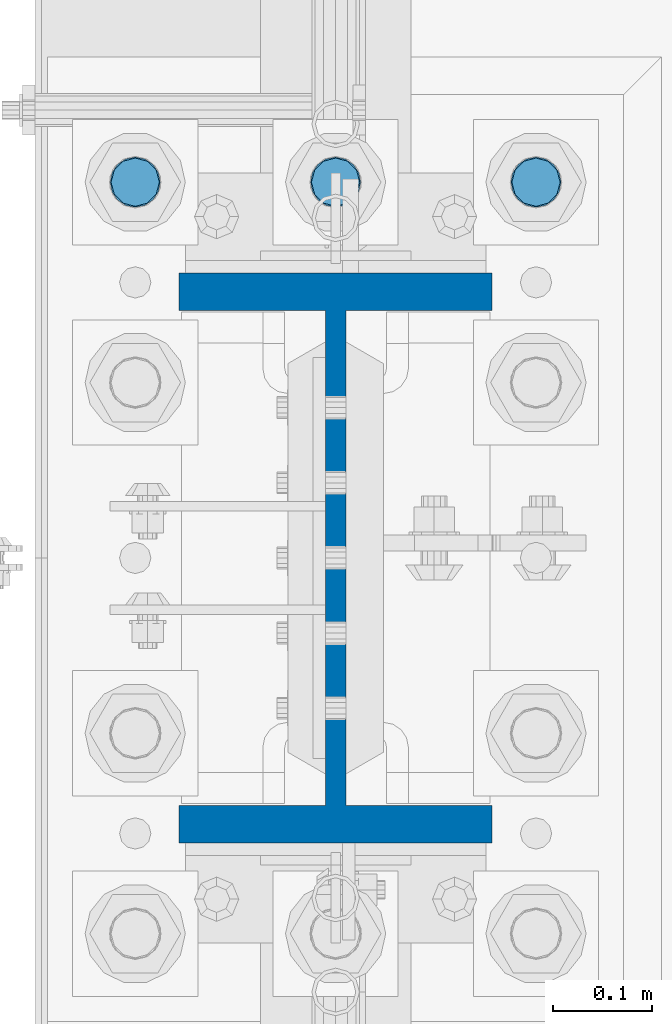
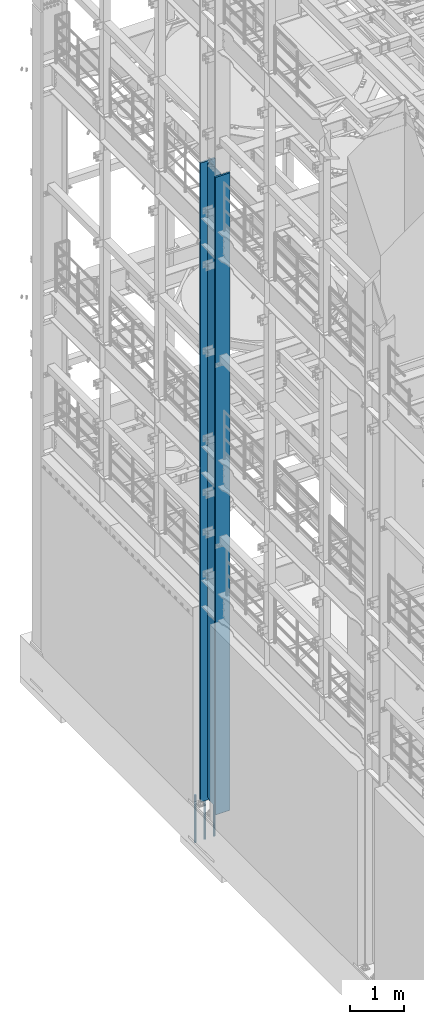
# One storey, part 732 of 1876: 4 columns, 2 elements without a shape of their own.
"""IFC2X3 building model written with IfcOpenShell, lengths in millimetres."""

from ifc_helpers import new_model, si_unit, frame, origin_with_axes, place, context, subcontext, project, spatial, faceted_brep, material, type_object, element, aggregate, save


model = new_model("IFC2X3")

# Units and contexts
model_context = context("Model", 3, precision=1e-05, world=origin_with_axes())
body_context = subcontext(model_context, "Body", "Model", "MODEL_VIEW")
ifc_project = project(units=[si_unit("LENGTHUNIT", "METRE", prefix="MILLI"), si_unit("AREAUNIT", "SQUARE_METRE"), si_unit("VOLUMEUNIT", "CUBIC_METRE"), si_unit("MASSUNIT", "GRAM", prefix="KILO"), si_unit("TIMEUNIT", "SECOND"), si_unit("PLANEANGLEUNIT", "RADIAN"), si_unit("SOLIDANGLEUNIT", "STERADIAN"), si_unit("THERMODYNAMICTEMPERATUREUNIT", "DEGREE_CELSIUS"), si_unit("LUMINOUSINTENSITYUNIT", "LUMEN")], contexts=[model_context])

# Site, building, storey
site_placement = place(None, origin_with_axes())
site = spatial("IfcSite", under=ifc_project, at=site_placement, CompositionType="ELEMENT")
building_placement = place(site_placement, origin_with_axes())
building = spatial("IfcBuilding", under=site, at=building_placement, Name="Undefined", CompositionType="ELEMENT")
storey_placement = place(building_placement, origin_with_axes())
storey = spatial("IfcBuildingStorey", under=building, at=storey_placement, Name="Undefined", CompositionType="ELEMENT", Elevation=0.0)

# Assembly, column
assembly_1_placement = place(storey_placement, origin_with_axes())
assembly_1 = element("IfcElementAssembly", 1, at=assembly_1_placement, inside=storey, Name="COLUMN", AssemblyPlace="NOTDEFINED", PredefinedType="RIGID_FRAME")
ifc_material_1 = material(Name="STEEL/A992")
column_type_1 = type_object("IfcColumnType", Name="W21X182", PredefinedType="NOTDEFINED")
column_1_placement = place(assembly_1_placement, frame((0.0, 7620.0, 0.0), z_axis=(0.0, 1.0, 0.0), x_axis=(0.0, 0.0, 1.0)))
column_1 = element("IfcColumn", 2, at=column_1_placement, type_object=column_type_1, material=ifc_material_1, Name="COLUMN", ObjectType="W21X182", context=body_context, shape_type="Brep", body=[
    faceted_brep([(115.887500412823, -10.3187499999967, 200.025000762939), (95.25, 10.31875, 200.025000762939), (95.25, 10.31875, -200.025000762939), (115.887500412823, -10.31875, -200.025000762939), (14528.8, -158.75, 288.925), (14528.8, 158.75, 288.925), (133.350000412822, 158.75, 288.925), (133.350000412824, -158.75, 288.925), (146.050000412824, -158.75, 250.825), (14478.0, -158.75, 250.825), (14528.8, -158.75, 250.825), (95.25, -158.75, 250.825), (146.050000412823, -10.3187500000004, 250.825), (14478.0, -10.3187500000004, 250.825), (14528.8, -10.3187500000004, 250.825), (95.25, -10.3187500000004, 250.825), (14528.8, -158.75, -288.925), (14528.8, -158.75, -250.825), (14478.0000007629, -158.75, -250.825), (146.050000412824, -158.75, -250.825), (95.25, -158.75, -250.825), (133.350000412824, -158.75, -288.925), (14528.8, 158.75, -288.925), (133.350000412822, 158.75, -288.925), (146.050000412824, 158.75, -250.825), (14478.0000007629, 158.75, -250.825), (14528.8, 158.75, -250.825), (95.25, 158.75, -250.825), (14528.8, 10.3187500000004, -250.825), (14528.8, -10.3187500000004, -250.825), (14478.0000007629, -10.3187500000004, -250.825), (146.050000412824, -10.3187500000004, -250.825), (95.25, -10.3187500000004, -250.825), (120.650000794293, -10.3187500000004, -200.025000762939), (120.650000794293, 10.3187500000004, -200.025000762939), (130.370159830384, 10.3187500000004, -201.958460608115), (130.370159830384, -10.3187500000004, -201.958460608115), (138.610512766692, 10.3187500000004, -207.464488409071), (138.610512766692, -10.3187500000004, -207.464488409071), (144.116540567648, 10.3187500000004, -215.704841345378), (144.116540567648, -10.3187500000004, -215.704841345378), (146.050000412823, 10.3187500000004, -225.42500038147), (146.050000412823, -10.3187500000004, -225.42500038147), (146.050000412824, 10.3187500000004, -250.825), (95.25, 10.3187500000004, -250.825), (14478.0000007629, 10.3187500000004, -250.825), (14481.8669204533, 10.3187500000004, -231.384681927818), (14481.8669204533, -10.3187500000004, -231.384681927818), (14492.8789760552, 10.3187500000004, -214.903976055203), (14492.8789760552, -10.3187500000004, -214.903976055203), (14509.3596819278, 10.3187500000004, -203.891920453291), (14509.3596819278, -10.3187500000004, -203.891920453291), (14528.8, -10.3187500000004, -200.025000762939), (14528.8, 10.3187500000004, -200.025000762939), (14528.8, 10.3187500000004, 200.025000762939), (14528.8, -10.3187500000004, 200.025000762939), (14509.3596811649, 10.3187500000004, 203.891920453291), (14509.3596811649, -10.3187500000004, 203.891920453291), (14492.8789752923, 10.3187500000004, 214.903976055203), (14492.8789752923, -10.3187500000004, 214.903976055203), (14481.8669196904, 10.3187500000004, 231.384681927818), (14481.8669196904, -10.3187500000004, 231.384681927818), (14478.0, 10.3187500000004, 250.825), (14528.8, 10.3187500000004, 250.825), (14528.8, 158.75, 250.825), (14478.0, 158.75, 250.825), (146.050000412824, 158.75, 250.825), (95.25, 158.75, 250.825), (95.25, 10.3187500000004, 250.825), (146.050000412824, 10.3187500000004, 250.825), (146.050000412823, 10.3187500000004, 225.42500038147), (146.050000412823, -10.3187500000004, 225.42500038147), (144.116540567648, 10.3187500000004, 215.704841345378), (144.116540567648, -10.3187500000004, 215.704841345378), (138.610512766692, 10.3187500000004, 207.464488409071), (138.610512766692, -10.3187500000004, 207.464488409071), (130.370159830384, 10.3187500000004, 201.958460608115), (130.370159830384, -10.3187500000004, 201.958460608115), (120.650000794293, 10.3187500000004, 200.025000762939), (120.650000794293, -10.3187500000004, 200.025000762939)], [[[0, 1, 2, 3]], [[4, 5, 6, 7]], [[8, 9, 10, 4, 7, 11]], [[12, 13, 14, 10, 9, 8, 11, 15]], [[16, 17, 18, 19, 20, 21]], [[22, 16, 21, 23]], [[24, 25, 26, 22, 23, 27]], [[17, 16, 22, 26, 28, 29]], [[19, 18, 17, 29, 30, 31, 32, 20]], [[33, 34, 35, 36]], [[36, 35, 37, 38]], [[38, 37, 39, 40]], [[40, 39, 41, 42]], [[42, 41, 43, 31]], [[31, 43, 44, 32]], [[27, 23, 21, 20, 32, 44]], [[43, 45, 28, 26, 25, 24, 27, 44]], [[29, 28, 45, 30]], [[30, 45, 46, 47]], [[47, 46, 48, 49]], [[49, 48, 50, 51]], [[52, 51, 50, 53]], [[54, 55, 52, 53]], [[55, 54, 56, 57]], [[57, 56, 58, 59]], [[59, 58, 60, 61]], [[61, 60, 62, 13]], [[14, 13, 62, 63]], [[64, 5, 4, 10, 14, 63]], [[5, 64, 65, 66, 67, 6]], [[11, 7, 6, 67, 68, 15]], [[66, 65, 64, 63, 62, 69, 68, 67]], [[15, 68, 69, 12]], [[12, 69, 70, 71]], [[71, 70, 72, 73]], [[73, 72, 74, 75]], [[75, 74, 76, 77]], [[77, 76, 78, 79]], [[33, 36, 38, 40, 42, 31, 30, 47, 49, 51, 52, 55, 57, 59, 61, 13, 12, 71, 73, 75, 77, 79, 0, 3]], [[34, 33, 3, 2]], [[78, 76, 74, 72, 70, 69, 62, 60, 58, 56, 54, 53, 50, 48, 46, 45, 43, 41, 39, 37, 35, 34, 2, 1]], [[79, 78, 1, 0]]]),
])
aggregate(assembly_1, [column_1])

# Assembly, columns
assembly_2_placement = place(storey_placement, origin_with_axes())
assembly_2 = element("IfcElementAssembly", 3, at=assembly_2_placement, inside=storey, Name="TEMPLATE", AssemblyPlace="NOTDEFINED", PredefinedType="RIGID_FRAME")
ifc_material_2 = material(Name="STEEL/F1554-GR.105")
column_type_2 = type_object("IfcColumnType", PredefinedType="NOTDEFINED")
column_2_placement = place(assembly_2_placement, frame((-203.2, 8001.0, 0.0), z_axis=(0.0, -1.0, 0.0), x_axis=(0.0, 0.0, -1.0)))
column_2 = element("IfcColumn", 4, at=column_2_placement, type_object=column_type_2, material=ifc_material_2, Name="ANCHOR_BOLTS", context=body_context, shape_type="Brep", body=[
    faceted_brep([(-196.85, -21.217622392719, 12.25), (-196.85, -12.25, 21.2176223927188), (-196.85, 0.0, 24.5), (-196.85, 12.25, 21.2176223927188), (-196.85, 21.217622392719, 12.25), (-196.85, 24.5, 0.0), (-196.85, 21.217622392719, -12.25), (-196.85, 12.25, -21.2176223927188), (-196.85, 0.0, -24.5), (-196.85, -12.25, -21.2176223927188), (-196.85, -21.217622392719, -12.25), (-196.85, -24.5, 0.0), (0.0, 24.5, 0.0), (0.0, 21.217622392719, -12.25), (0.0, 12.25, -21.2176223927188), (0.0, 0.0, -24.5), (0.0, -12.25, -21.2176223927188), (0.0, -21.217622392719, -12.25), (0.0, -24.5, 0.0), (0.0, -21.217622392719, 12.25), (0.0, -12.25, 21.2176223927188), (0.0, 0.0, 24.5), (0.0, 12.25, 21.2176223927188), (0.0, 21.217622392719, 12.25), (0.0, -23.4665401257871, 9.7201591820733), (0.0, -17.9605122421381, 17.9605122421383), (0.0, -9.72015918207308, 23.4665401257867), (0.0, 0.0, 25.4000000000001), (0.0, 9.72015918207308, 23.4665401257867), (0.0, 17.9605122421381, 17.9605122421383), (0.0, 23.4665401257871, 9.7201591820733), (0.0, 25.3999996185339, 9.09494701772928e-13), (0.0, 23.4665401257871, -9.7201591820733), (0.0, 17.9605122421381, -17.9605122421383), (0.0, 9.72015918207308, -23.4665401257867), (0.0, 0.0, -25.4000000000001), (0.0, -9.72015918207308, -23.4665401257867), (0.0, -17.9605122421381, -17.9605122421383), (0.0, -23.4665401257871, -9.7201591820733), (0.0, -25.3999996185375, 0.0), (673.1, -25.3999999999996, 0.0), (673.1, -23.4665401257871, 9.7201591820733), (673.1, -17.9605122421381, 17.9605122421383), (673.1, -9.72015918207308, 23.4665401257867), (673.1, 0.0, 25.4000000000001), (673.1, 9.72015918207308, 23.4665401257867), (673.1, 17.9605122421381, 17.9605122421383), (673.1, 23.4665401257871, 9.7201591820733), (673.1, 25.3999999999996, 0.0), (673.1, 23.4665401257871, -9.7201591820733), (673.1, 17.9605122421381, -17.9605122421383), (673.1, 9.72015918207308, -23.4665401257867), (673.1, 0.0, -25.4000000000001), (673.1, -9.72015918207308, -23.4665401257867), (673.1, -17.9605122421381, -17.9605122421383), (673.1, -23.4665401257871, -9.7201591820733), (673.1, -12.25, 21.2176223927188), (673.1, 0.0, 24.5), (673.1, 12.25, 21.2176223927188), (673.1, 21.217622392719, 12.25), (673.1, 24.5, 0.0), (673.1, 21.217622392719, -12.25), (673.1, 12.25, -21.2176223927188), (673.1, 0.0, -24.5), (673.1, -12.25, -21.2176223927188), (673.1, -21.217622392719, -12.25), (673.1, -24.5, 0.0), (673.1, -21.217622392719, 12.25), (869.95, -12.25, -21.2176223927188), (869.95, 0.0, -24.5), (869.95, 12.25, -21.2176223927188), (869.95, 21.217622392719, -12.25), (869.95, 24.5, 0.0), (869.95, 21.217622392719, 12.25), (869.95, 12.25, 21.2176223927188), (869.95, 0.0, 24.5), (869.95, -12.25, 21.2176223927188), (869.95, -21.217622392719, 12.25), (869.95, -24.5, 0.0), (869.95, -21.217622392719, -12.25)], [[[0, 1, 2, 3, 4, 5, 6, 7, 8, 9, 10, 11]], [[6, 5, 12, 13]], [[7, 6, 13, 14]], [[8, 7, 14, 15]], [[9, 8, 15, 16]], [[10, 9, 16, 17]], [[11, 10, 17, 18]], [[0, 11, 18, 19]], [[1, 0, 19, 20]], [[2, 1, 20, 21]], [[3, 2, 21, 22]], [[4, 3, 22, 23]], [[5, 4, 23, 12]], [[24, 25, 26, 27, 28, 29, 30, 31, 32, 33, 34, 35, 36, 37, 38, 39], [22, 21, 20, 19, 18, 17, 16, 15, 14, 13, 12, 23]], [[24, 39, 40, 41]], [[25, 24, 41, 42]], [[26, 25, 42, 43]], [[27, 26, 43, 44]], [[28, 27, 44, 45]], [[29, 28, 45, 46]], [[30, 29, 46, 47]], [[31, 30, 47, 48]], [[32, 31, 48, 49]], [[33, 32, 49, 50]], [[34, 33, 50, 51]], [[35, 34, 51, 52]], [[36, 35, 52, 53]], [[37, 36, 53, 54]], [[38, 37, 54, 55]], [[39, 38, 55, 40]], [[54, 53, 52, 51, 50, 49, 48, 47, 46, 45, 44, 43, 42, 41, 40, 55], [56, 57, 58, 59, 60, 61, 62, 63, 64, 65, 66, 67]], [[68, 69, 70, 71, 72, 73, 74, 75, 76, 77, 78, 79]], [[76, 75, 57, 56]], [[77, 76, 56, 67]], [[78, 77, 67, 66]], [[79, 78, 66, 65]], [[68, 79, 65, 64]], [[69, 68, 64, 63]], [[70, 69, 63, 62]], [[71, 70, 62, 61]], [[72, 71, 61, 60]], [[73, 72, 60, 59]], [[74, 73, 59, 58]], [[75, 74, 58, 57]]]),
])
column_3_placement = place(assembly_2_placement, frame((0.0, 8001.0, 0.0), z_axis=(0.0, -1.0, 0.0), x_axis=(0.0, 0.0, -1.0)))
column_3 = element("IfcColumn", 5, at=column_3_placement, type_object=column_type_2, material=ifc_material_2, Name="ANCHOR_BOLTS", context=body_context, shape_type="Brep", body=[
    faceted_brep([(-196.85, -21.217622392719, 12.25), (-196.85, -12.25, 21.2176223927188), (-196.85, 0.0, 24.5), (-196.85, 12.25, 21.2176223927188), (-196.85, 21.217622392719, 12.25), (-196.85, 24.5, 0.0), (-196.85, 21.217622392719, -12.25), (-196.85, 12.25, -21.2176223927188), (-196.85, 0.0, -24.5), (-196.85, -12.25, -21.2176223927188), (-196.85, -21.217622392719, -12.25), (-196.85, -24.5, 0.0), (0.0, 24.5, 0.0), (0.0, 21.217622392719, -12.25), (0.0, 12.25, -21.2176223927188), (0.0, 0.0, -24.5), (0.0, -12.25, -21.2176223927188), (0.0, -21.217622392719, -12.25), (0.0, -24.5, 0.0), (0.0, -21.217622392719, 12.25), (0.0, -12.25, 21.2176223927188), (0.0, 0.0, 24.5), (0.0, 12.25, 21.2176223927188), (0.0, 21.217622392719, 12.25), (0.0, -23.4665401257871, 9.7201591820733), (0.0, -17.9605122421381, 17.9605122421383), (0.0, -9.72015918207308, 23.4665401257867), (0.0, 0.0, 25.4000000000001), (0.0, 9.72015918207308, 23.4665401257867), (0.0, 17.9605122421381, 17.9605122421383), (0.0, 23.4665401257871, 9.7201591820733), (0.0, 25.3999996185339, 9.09494701772928e-13), (0.0, 23.4665401257871, -9.7201591820733), (0.0, 17.9605122421381, -17.9605122421383), (0.0, 9.72015918207308, -23.4665401257867), (0.0, 0.0, -25.4000000000001), (0.0, -9.72015918207308, -23.4665401257867), (0.0, -17.9605122421381, -17.9605122421383), (0.0, -23.4665401257871, -9.7201591820733), (0.0, -25.3999996185375, 0.0), (673.1, -25.3999999999996, 0.0), (673.1, -23.4665401257871, 9.7201591820733), (673.1, -17.9605122421381, 17.9605122421383), (673.1, -9.72015918207308, 23.4665401257867), (673.1, 0.0, 25.4000000000001), (673.1, 9.72015918207308, 23.4665401257867), (673.1, 17.9605122421381, 17.9605122421383), (673.1, 23.4665401257871, 9.7201591820733), (673.1, 25.3999999999996, 0.0), (673.1, 23.4665401257871, -9.7201591820733), (673.1, 17.9605122421381, -17.9605122421383), (673.1, 9.72015918207308, -23.4665401257867), (673.1, 0.0, -25.4000000000001), (673.1, -9.72015918207308, -23.4665401257867), (673.1, -17.9605122421381, -17.9605122421383), (673.1, -23.4665401257871, -9.7201591820733), (673.1, -12.25, 21.2176223927188), (673.1, 0.0, 24.5), (673.1, 12.25, 21.2176223927188), (673.1, 21.217622392719, 12.25), (673.1, 24.5, 0.0), (673.1, 21.217622392719, -12.25), (673.1, 12.25, -21.2176223927188), (673.1, 0.0, -24.5), (673.1, -12.25, -21.2176223927188), (673.1, -21.217622392719, -12.25), (673.1, -24.5, 0.0), (673.1, -21.217622392719, 12.25), (869.95, -12.25, -21.2176223927188), (869.95, 0.0, -24.5), (869.95, 12.25, -21.2176223927188), (869.95, 21.217622392719, -12.25), (869.95, 24.5, 0.0), (869.95, 21.217622392719, 12.25), (869.95, 12.25, 21.2176223927188), (869.95, 0.0, 24.5), (869.95, -12.25, 21.2176223927188), (869.95, -21.217622392719, 12.25), (869.95, -24.5, 0.0), (869.95, -21.217622392719, -12.25)], [[[0, 1, 2, 3, 4, 5, 6, 7, 8, 9, 10, 11]], [[6, 5, 12, 13]], [[7, 6, 13, 14]], [[8, 7, 14, 15]], [[9, 8, 15, 16]], [[10, 9, 16, 17]], [[11, 10, 17, 18]], [[0, 11, 18, 19]], [[1, 0, 19, 20]], [[2, 1, 20, 21]], [[3, 2, 21, 22]], [[4, 3, 22, 23]], [[5, 4, 23, 12]], [[24, 25, 26, 27, 28, 29, 30, 31, 32, 33, 34, 35, 36, 37, 38, 39], [22, 21, 20, 19, 18, 17, 16, 15, 14, 13, 12, 23]], [[24, 39, 40, 41]], [[25, 24, 41, 42]], [[26, 25, 42, 43]], [[27, 26, 43, 44]], [[28, 27, 44, 45]], [[29, 28, 45, 46]], [[30, 29, 46, 47]], [[31, 30, 47, 48]], [[32, 31, 48, 49]], [[33, 32, 49, 50]], [[34, 33, 50, 51]], [[35, 34, 51, 52]], [[36, 35, 52, 53]], [[37, 36, 53, 54]], [[38, 37, 54, 55]], [[39, 38, 55, 40]], [[54, 53, 52, 51, 50, 49, 48, 47, 46, 45, 44, 43, 42, 41, 40, 55], [56, 57, 58, 59, 60, 61, 62, 63, 64, 65, 66, 67]], [[68, 69, 70, 71, 72, 73, 74, 75, 76, 77, 78, 79]], [[76, 75, 57, 56]], [[77, 76, 56, 67]], [[78, 77, 67, 66]], [[79, 78, 66, 65]], [[68, 79, 65, 64]], [[69, 68, 64, 63]], [[70, 69, 63, 62]], [[71, 70, 62, 61]], [[72, 71, 61, 60]], [[73, 72, 60, 59]], [[74, 73, 59, 58]], [[75, 74, 58, 57]]]),
])
column_4_placement = place(assembly_2_placement, frame((203.2, 8001.0, 0.0), z_axis=(0.0, 1.0, 0.0), x_axis=(0.0, 0.0, -1.0)))
column_4 = element("IfcColumn", 6, at=column_4_placement, type_object=column_type_2, material=ifc_material_2, Name="ANCHOR_BOLTS", context=body_context, shape_type="Brep", body=[
    faceted_brep([(-196.85, -21.217622392719, 12.25), (-196.85, -12.25, 21.2176223927188), (-196.85, 0.0, 24.5), (-196.85, 12.25, 21.2176223927188), (-196.85, 21.217622392719, 12.25), (-196.85, 24.5, 0.0), (-196.85, 21.217622392719, -12.25), (-196.85, 12.25, -21.2176223927188), (-196.85, 0.0, -24.5), (-196.85, -12.25, -21.2176223927188), (-196.85, -21.217622392719, -12.25), (-196.85, -24.5, 0.0), (0.0, 24.5, 0.0), (0.0, 21.217622392719, -12.25), (0.0, 12.25, -21.2176223927188), (0.0, 0.0, -24.5), (0.0, -12.25, -21.2176223927188), (0.0, -21.217622392719, -12.25), (0.0, -24.5, 0.0), (0.0, -21.217622392719, 12.25), (0.0, -12.25, 21.2176223927188), (0.0, 0.0, 24.5), (0.0, 12.25, 21.2176223927188), (0.0, 21.217622392719, 12.25), (0.0, -23.4665401257871, 9.7201591820733), (0.0, -17.9605122421381, 17.9605122421383), (0.0, -9.72015918207308, 23.4665401257867), (0.0, 0.0, 25.4000000000001), (0.0, 9.72015918207308, 23.4665401257867), (0.0, 17.9605122421381, 17.9605122421383), (0.0, 23.4665401257871, 9.7201591820733), (0.0, 25.3999996185339, 9.09494701772928e-13), (0.0, 23.4665401257871, -9.7201591820733), (0.0, 17.9605122421381, -17.9605122421383), (0.0, 9.72015918207308, -23.4665401257867), (0.0, 0.0, -25.4000000000001), (0.0, -9.72015918207308, -23.4665401257867), (0.0, -17.9605122421381, -17.9605122421383), (0.0, -23.4665401257871, -9.7201591820733), (0.0, -25.3999996185375, 0.0), (673.1, -25.3999999999996, 0.0), (673.1, -23.4665401257871, 9.7201591820733), (673.1, -17.9605122421381, 17.9605122421383), (673.1, -9.72015918207308, 23.4665401257867), (673.1, 0.0, 25.4000000000001), (673.1, 9.72015918207308, 23.4665401257867), (673.1, 17.9605122421381, 17.9605122421383), (673.1, 23.4665401257871, 9.7201591820733), (673.1, 25.3999999999996, 0.0), (673.1, 23.4665401257871, -9.7201591820733), (673.1, 17.9605122421381, -17.9605122421383), (673.1, 9.72015918207308, -23.4665401257867), (673.1, 0.0, -25.4000000000001), (673.1, -9.72015918207308, -23.4665401257867), (673.1, -17.9605122421381, -17.9605122421383), (673.1, -23.4665401257871, -9.7201591820733), (673.1, -12.25, 21.2176223927188), (673.1, 0.0, 24.5), (673.1, 12.25, 21.2176223927188), (673.1, 21.217622392719, 12.25), (673.1, 24.5, 0.0), (673.1, 21.217622392719, -12.25), (673.1, 12.25, -21.2176223927188), (673.1, 0.0, -24.5), (673.1, -12.25, -21.2176223927188), (673.1, -21.217622392719, -12.25), (673.1, -24.5, 0.0), (673.1, -21.217622392719, 12.25), (869.95, -12.25, -21.2176223927188), (869.95, 0.0, -24.5), (869.95, 12.25, -21.2176223927188), (869.95, 21.217622392719, -12.25), (869.95, 24.5, 0.0), (869.95, 21.217622392719, 12.25), (869.95, 12.25, 21.2176223927188), (869.95, 0.0, 24.5), (869.95, -12.25, 21.2176223927188), (869.95, -21.217622392719, 12.25), (869.95, -24.5, 0.0), (869.95, -21.217622392719, -12.25)], [[[0, 1, 2, 3, 4, 5, 6, 7, 8, 9, 10, 11]], [[6, 5, 12, 13]], [[7, 6, 13, 14]], [[8, 7, 14, 15]], [[9, 8, 15, 16]], [[10, 9, 16, 17]], [[11, 10, 17, 18]], [[0, 11, 18, 19]], [[1, 0, 19, 20]], [[2, 1, 20, 21]], [[3, 2, 21, 22]], [[4, 3, 22, 23]], [[5, 4, 23, 12]], [[24, 25, 26, 27, 28, 29, 30, 31, 32, 33, 34, 35, 36, 37, 38, 39], [22, 21, 20, 19, 18, 17, 16, 15, 14, 13, 12, 23]], [[24, 39, 40, 41]], [[25, 24, 41, 42]], [[26, 25, 42, 43]], [[27, 26, 43, 44]], [[28, 27, 44, 45]], [[29, 28, 45, 46]], [[30, 29, 46, 47]], [[31, 30, 47, 48]], [[32, 31, 48, 49]], [[33, 32, 49, 50]], [[34, 33, 50, 51]], [[35, 34, 51, 52]], [[36, 35, 52, 53]], [[37, 36, 53, 54]], [[38, 37, 54, 55]], [[39, 38, 55, 40]], [[54, 53, 52, 51, 50, 49, 48, 47, 46, 45, 44, 43, 42, 41, 40, 55], [56, 57, 58, 59, 60, 61, 62, 63, 64, 65, 66, 67]], [[68, 69, 70, 71, 72, 73, 74, 75, 76, 77, 78, 79]], [[76, 75, 57, 56]], [[77, 76, 56, 67]], [[78, 77, 67, 66]], [[79, 78, 66, 65]], [[68, 79, 65, 64]], [[69, 68, 64, 63]], [[70, 69, 63, 62]], [[71, 70, 62, 61]], [[72, 71, 61, 60]], [[73, 72, 60, 59]], [[74, 73, 59, 58]], [[75, 74, 58, 57]]]),
])
aggregate(assembly_2, [column_2, column_3, column_4])

save(model, "model.ifc")
